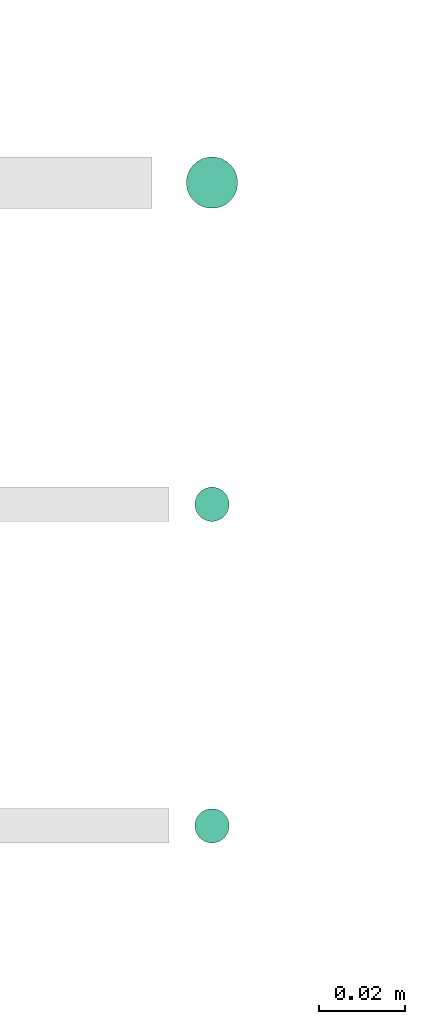
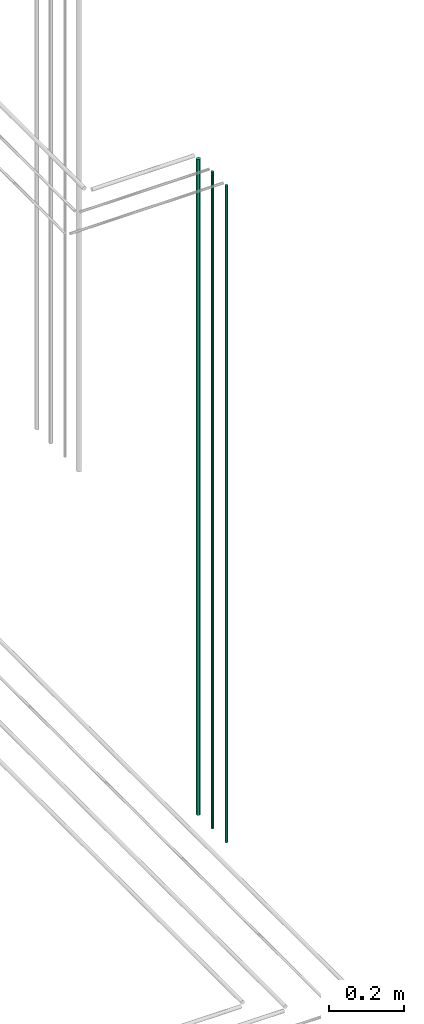
# One storey, part 65 of 331: 3 flow segments.
"""IFC2X3 building model written with IfcOpenShell, lengths in millimetres."""

import ifcopenshell
import ifcopenshell.guid

model = None  # the IFC model being written
_history = None  # IfcOwnerHistory: only IFC2X3 demands one
_inside = {}  # id of a spatial element -> (the spatial element, [elements in it])
_under = {}  # id of a project, library or spatial element -> (it, [spatial elements below it])
_declared = {}  # id of a project -> (the project, [libraries it declares])
_typed = {}  # id of a type object -> (the type object, [elements of that type])
_made_of = {}  # id of a material, layer set ... -> (it, [elements and type objects made of it])


def new_model(schema):
    """Start an empty IFC model of exactly this schema.

    Asked for "IFC4X3", IfcOpenShell would pick the latest addendum, in which some entities
    have other attributes; the version numbers below select the first issue.
    IFC2X3 requires an IfcOwnerHistory on every rooted entity: one is made here for all.
    """
    global model, _history
    if schema == "IFC4X3":
        model = ifcopenshell.file(schema_version=(4, 3, 0, 0))
    else:
        model = ifcopenshell.file(schema=schema)
    _inside.clear()
    _under.clear()
    _declared.clear()
    _typed.clear()
    _made_of.clear()
    _history = None
    if model.schema == "IFC2X3":
        org = make("IfcOrganization", Name="unknown")
        user = make(
            "IfcPersonAndOrganization",
            ThePerson=make("IfcPerson", FamilyName="unknown"),
            TheOrganization=org,
        )
        app = make(
            "IfcApplication",
            ApplicationDeveloper=org,
            Version="unknown",
            ApplicationFullName="unknown",
            ApplicationIdentifier="unknown",
        )
        _history = make(
            "IfcOwnerHistory",
            OwningUser=user,
            OwningApplication=app,
            ChangeAction="ADDED",
            CreationDate=0,
        )
    return model


def make(cls, **values):
    """One entity of the class cls with the attributes given. An attribute that is None is left unset."""
    return model.create_entity(
        cls, **{name: value for name, value in values.items() if value is not None}
    )


def entity(cls, *values):
    """Any entity or typed value of the class cls, its attributes in the order of the schema. None: left unset."""
    e = model.create_entity(cls)
    for i, value in enumerate(values):
        if value is not None:
            e[i] = value
    return e


def rooted(cls, **values):
    """An entity with a GlobalId (a new one), such as an element, a storey or a relation."""
    return make(cls, GlobalId=ifcopenshell.guid.new(), OwnerHistory=_history, **values)


def si_unit(unit_type, name, prefix=None):
    """IfcSIUnit, for example si_unit("LENGTHUNIT", "METRE", prefix="MILLI")."""
    return make("IfcSIUnit", UnitType=unit_type, Prefix=prefix, Name=name)


def converted_unit(unit_type, name, factor, base, dimensions=None, offset=None):
    """IfcConversionBasedUnit, such as the inch: factor (a typed value) times the base unit."""
    return make(
        "IfcConversionBasedUnit"
        if offset is None
        else "IfcConversionBasedUnitWithOffset",
        ConversionOffset=offset,
        Dimensions=None
        if dimensions is None
        else entity("IfcDimensionalExponents", *dimensions),
        UnitType=unit_type,
        Name=name,
        ConversionFactor=make(
            "IfcMeasureWithUnit", ValueComponent=factor, UnitComponent=base
        ),
    )


def derived_unit(unit_type, elements):
    """IfcDerivedUnit: a product of units, each with its exponent."""
    return make(
        "IfcDerivedUnit",
        Elements=[
            make("IfcDerivedUnitElement", Unit=unit, Exponent=power)
            for unit, power in elements
        ],
        UnitType=unit_type,
    )


def assignment(units):
    """IfcUnitAssignment: the units of a project."""
    return None if units is None else make("IfcUnitAssignment", Units=units)


def point(xyz):
    """IfcCartesianPoint."""
    return None if xyz is None else make("IfcCartesianPoint", Coordinates=xyz)


def direction(xyz):
    """IfcDirection."""
    return None if xyz is None else make("IfcDirection", DirectionRatios=xyz)


def frame(location, z_axis=None, x_axis=None):
    """IfcAxis2Placement3D, a coordinate frame: its origin and axes. An axis left out is left unset."""
    return make(
        "IfcAxis2Placement3D",
        Location=point(location),
        Axis=direction(z_axis),
        RefDirection=direction(x_axis),
    )


def frame_2d(location, x_axis=None):
    """IfcAxis2Placement2D, a coordinate frame in the plane: its origin and x axis."""
    return make(
        "IfcAxis2Placement2D", Location=point(location), RefDirection=direction(x_axis)
    )


def origin():
    """The frame at (0, 0, 0) with its axes left unset."""
    return frame((0.0, 0.0, 0.0))


def origin_2d_with_axis():
    """The frame at (0, 0) in the plane with the x axis (1, 0) written out."""
    return frame_2d((0.0, 0.0), x_axis=(1.0, 0.0))


def place(relative_to, where):
    """IfcLocalPlacement: puts the frame where relative to a parent placement (None: the world)."""
    return make(
        "IfcLocalPlacement", PlacementRelTo=relative_to, RelativePlacement=where
    )


def context(
    kind, dimensions, precision=None, world=None, true_north=None, identifier=None
):
    """IfcGeometricRepresentationContext, for example the 3D "Model" context."""
    return make(
        "IfcGeometricRepresentationContext",
        ContextIdentifier=identifier,
        ContextType=kind,
        CoordinateSpaceDimension=dimensions,
        Precision=precision,
        WorldCoordinateSystem=world,
        TrueNorth=true_north,
    )


def subcontext(parent, identifier, kind, view, scale=None):
    """IfcGeometricRepresentationSubContext, for example "Body" below "Model"."""
    return make(
        "IfcGeometricRepresentationSubContext",
        ContextIdentifier=identifier,
        ContextType=kind,
        ParentContext=parent,
        TargetScale=scale,
        TargetView=view,
    )


def project(units=None, contexts=None):
    """IfcProject with its units and contexts."""
    return rooted(
        "IfcProject",
        Name="project",
        RepresentationContexts=contexts,
        UnitsInContext=assignment(units),
    )


def spatial(cls, under=None, at=None, **own):
    """A site, building, storey or space (cls), placed at a placement, below another one or the project."""
    s = rooted(cls, ObjectPlacement=at, **own)
    if under is not None:
        _under.setdefault(under.id(), (under, []))[1].append(s)
    return s


def profile(cls, at=None, kind="AREA", **sizes):
    """A parametric profile (cls). Its sizes go by their IFC names, for example OverallWidth=200.0."""
    return make(cls, ProfileType=kind, Position=at, **sizes)


def circle(**sizes):
    """IfcCircleProfileDef."""
    return profile("IfcCircleProfileDef", **sizes)


def extrude(swept, where, along, depth):
    """IfcExtrudedAreaSolid: the profile swept, set in the frame where, extruded along a direction by depth."""
    return make(
        "IfcExtrudedAreaSolid",
        SweptArea=swept,
        Position=where,
        ExtrudedDirection=direction(along),
        Depth=depth,
    )


def shape(context_of_items, identifier, shape_type, items):
    """IfcShapeRepresentation: the items that make up one representation, for example the "Body"."""
    return make(
        "IfcShapeRepresentation",
        ContextOfItems=context_of_items,
        RepresentationIdentifier=identifier,
        RepresentationType=shape_type,
        Items=items,
    )


def made_of(thing, what):
    """Note that an element or type object is made of a material, layer set ...; save() writes the relation."""
    if what is not None:
        _made_of.setdefault(what.id(), (what, []))[1].append(thing)
    return thing


def type_object(cls, material=None, **own):
    """A type object (cls), such as IfcWallType, which elements share."""
    return made_of(rooted(cls, **own), material)


def element(
    cls,
    number,
    at=None,
    inside=None,
    cuts=None,
    type_object=None,
    material=None,
    context=None,
    identifier="Body",
    shape_type=None,
    held_by="IfcProductDefinitionShape",
    body=None,
    shapes=None,
    **own,
):
    """One element of the class cls, such as IfcWall. Its Tag is "e" and its number.

    at: its placement. inside: the storey or other place that contains it. cuts: it is an
    opening in that element (IfcRelVoidsElement). A single representation is given by context,
    identifier, shape_type and body (its items); several are given by shapes. held_by: the class
    of the entity that holds the representations. save() writes the other relations.
    """
    e = rooted(cls, Tag="e%d" % number, ObjectPlacement=at, **own)
    if body is not None:
        shapes = [shape(context, identifier, shape_type, body)]
    if shapes is not None:
        e.Representation = make(held_by, Representations=shapes)
    if inside is not None:
        _inside.setdefault(inside.id(), (inside, []))[1].append(e)
    if cuts is not None:
        rooted(
            "IfcRelVoidsElement", RelatingBuildingElement=cuts, RelatedOpeningElement=e
        )
    if type_object is not None:
        _typed.setdefault(type_object.id(), (type_object, []))[1].append(e)
    return made_of(e, material)


def aggregate(whole, parts):
    """IfcRelAggregates: a whole, such as a stair, and the parts it consists of."""
    return rooted("IfcRelAggregates", RelatingObject=whole, RelatedObjects=parts)


def save(model, path):
    """Write the relations noted so far, then the file.

    IfcRelAggregates (storeys below a building ...), IfcRelContainedInSpatialStructure (elements
    in a storey), IfcRelDefinesByType, IfcRelAssociatesMaterial and IfcRelDeclares: one each for
    every whole, place, type object, material and project.
    """
    for whole, parts in _under.values():
        aggregate(whole, parts)
    for where, things in _inside.values():
        rooted(
            "IfcRelContainedInSpatialStructure",
            RelatedElements=things,
            RelatingStructure=where,
        )
    for kind, things in _typed.values():
        rooted("IfcRelDefinesByType", RelatedObjects=things, RelatingType=kind)
    for what, things in _made_of.values():
        rooted("IfcRelAssociatesMaterial", RelatedObjects=things, RelatingMaterial=what)
    for by, libraries in _declared.values():
        rooted("IfcRelDeclares", RelatingContext=by, RelatedDefinitions=libraries)
    model.write(path)


model = new_model("IFC2X3")

# Units and contexts
model_context = context("Model", 3, precision=0.01, world=origin(), true_north=direction((6.12303176911189e-17, 1.0)))
body_context = subcontext(model_context, "Body", "Model", "MODEL_VIEW")
ifc_project = project(units=[si_unit("LENGTHUNIT", "METRE", prefix="MILLI"), si_unit("AREAUNIT", "SQUARE_METRE"), si_unit("VOLUMEUNIT", "CUBIC_METRE"), converted_unit("PLANEANGLEUNIT", "DEGREE", entity("IfcRatioMeasure", 0.0174532925199433), si_unit("PLANEANGLEUNIT", "RADIAN"), dimensions=[0, 0, 0, 0, 0, 0, 0]), si_unit("MASSUNIT", "GRAM", prefix="KILO"), derived_unit("MASSDENSITYUNIT", [(si_unit("MASSUNIT", "GRAM", prefix="KILO"), 1), (si_unit("LENGTHUNIT", "METRE"), -3)]), derived_unit("MOMENTOFINERTIAUNIT", [(si_unit("LENGTHUNIT", "METRE"), 4)]), si_unit("TIMEUNIT", "SECOND"), si_unit("FREQUENCYUNIT", "HERTZ"), si_unit("THERMODYNAMICTEMPERATUREUNIT", "DEGREE_CELSIUS"), derived_unit("THERMALTRANSMITTANCEUNIT", [(si_unit("MASSUNIT", "GRAM", prefix="KILO"), 1), (si_unit("THERMODYNAMICTEMPERATUREUNIT", "KELVIN"), -1), (si_unit("TIMEUNIT", "SECOND"), -3)]), derived_unit("VOLUMETRICFLOWRATEUNIT", [(si_unit("LENGTHUNIT", "METRE"), 3), (si_unit("TIMEUNIT", "SECOND"), -1)]), derived_unit("MASSFLOWRATEUNIT", [(si_unit("MASSUNIT", "GRAM", prefix="KILO"), 1), (si_unit("TIMEUNIT", "SECOND"), -1)]), derived_unit("ROTATIONALFREQUENCYUNIT", [(si_unit("TIMEUNIT", "SECOND"), -1)]), si_unit("ELECTRICCURRENTUNIT", "AMPERE"), si_unit("ELECTRICVOLTAGEUNIT", "VOLT"), si_unit("POWERUNIT", "WATT"), si_unit("FORCEUNIT", "NEWTON", prefix="KILO"), si_unit("ILLUMINANCEUNIT", "LUX"), si_unit("LUMINOUSFLUXUNIT", "LUMEN"), si_unit("LUMINOUSINTENSITYUNIT", "CANDELA"), derived_unit("USERDEFINED", [(si_unit("MASSUNIT", "GRAM", prefix="KILO"), -1), (si_unit("LENGTHUNIT", "METRE"), -2), (si_unit("TIMEUNIT", "SECOND"), 3), (si_unit("LUMINOUSFLUXUNIT", "LUMEN"), 1)]), derived_unit("LINEARVELOCITYUNIT", [(si_unit("LENGTHUNIT", "METRE"), 1), (si_unit("TIMEUNIT", "SECOND"), -1)]), si_unit("PRESSUREUNIT", "PASCAL"), derived_unit("USERDEFINED", [(si_unit("LENGTHUNIT", "METRE"), -2), (si_unit("MASSUNIT", "GRAM", prefix="KILO"), 1), (si_unit("TIMEUNIT", "SECOND"), -2)]), derived_unit("LINEARFORCEUNIT", [(si_unit("MASSUNIT", "GRAM", prefix="KILO"), 1), (si_unit("LENGTHUNIT", "METRE"), 1), (si_unit("TIMEUNIT", "SECOND"), -2), (si_unit("LENGTHUNIT", "METRE"), -1)]), derived_unit("PLANARFORCEUNIT", [(si_unit("MASSUNIT", "GRAM", prefix="KILO"), 1), (si_unit("LENGTHUNIT", "METRE"), 1), (si_unit("TIMEUNIT", "SECOND"), -2), (si_unit("LENGTHUNIT", "METRE"), -2)])], contexts=[model_context])

# Site, building, storey
site_placement = place(None, frame((0.0, -0.00077364408347762, 0.0)))
site = spatial("IfcSite", under=ifc_project, at=site_placement, CompositionType="ELEMENT")
building_placement = place(site_placement, origin())
building = spatial("IfcBuilding", under=site, at=building_placement, CompositionType="ELEMENT")
storey_placement = place(building_placement, origin())
storey = spatial("IfcBuildingStorey", under=building, at=storey_placement, CompositionType="ELEMENT", Elevation=0.0)

# Flow segments
pipe_segment_type = type_object("IfcPipeSegmentType", PredefinedType="NOTDEFINED")
flow_segment_1_placement = place(storey_placement, frame((62356.8310109464, 1343.89349484373, 16890.0)))
element("IfcFlowSegment", 1, at=flow_segment_1_placement, inside=storey, type_object=pipe_segment_type, context=body_context, shape_type="SweptSolid", body=[
    extrude(circle(Radius=6.0, at=origin_2d_with_axis()), frame((7.59527223591454, 7.59527223591589, 0.0)), (0.0, 0.0, 1.0), 2146.0),
])
flow_segment_2_placement = place(storey_placement, frame((62358.8310109464, 1270.89349484373, 16890.0)))
element("IfcFlowSegment", 2, at=flow_segment_2_placement, inside=storey, type_object=pipe_segment_type, context=body_context, shape_type="SweptSolid", body=[
    extrude(circle(Radius=4.0, at=origin_2d_with_axis()), frame((5.59527223591499, 5.5952722359158, 0.0)), (0.0, 0.0, 1.0), 2150.00000000001),
])
flow_segment_3_placement = place(storey_placement, frame((62358.8310109464, 1195.89349484373, 16890.0)))
element("IfcFlowSegment", 3, at=flow_segment_3_placement, inside=storey, type_object=pipe_segment_type, context=body_context, shape_type="SweptSolid", body=[
    extrude(circle(Radius=4.0, at=origin_2d_with_axis()), frame((5.59527223591499, 5.59527223591607, 0.0)), (0.0, 0.0, 1.0), 2150.00000000001),
])

save(model, "model.ifc")
